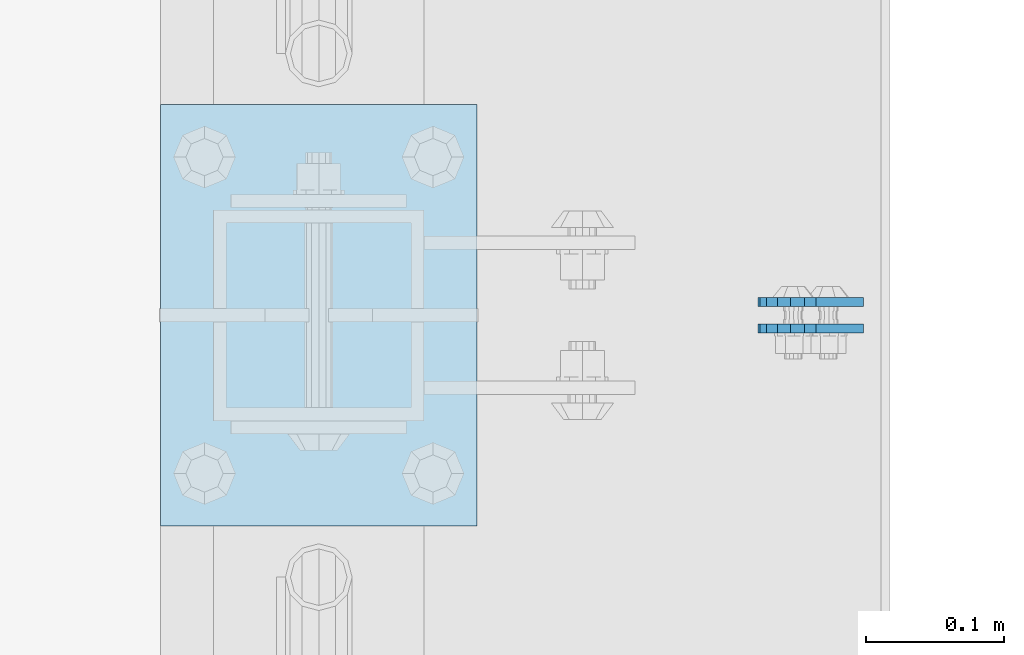
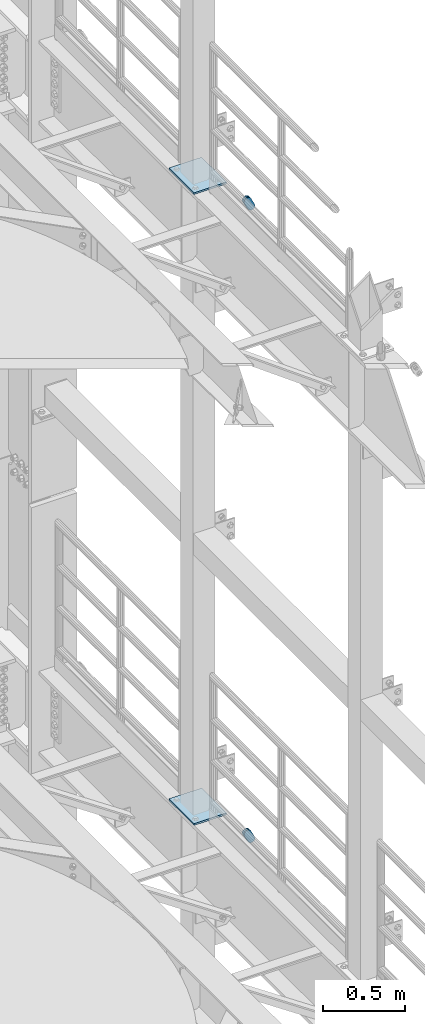
# One storey, part 1669 of 1876: 6 plates, 6 elements without a shape of their own.
"""IFC2X3 building model written with IfcOpenShell, lengths in millimetres."""

from ifc_helpers import new_model, si_unit, frame, origin_with_axes, place, context, subcontext, project, spatial, faceted_brep, material, type_object, element, aggregate, save


model = new_model("IFC2X3")

# Units and contexts
model_context = context("Model", 3, precision=1e-05, world=origin_with_axes())
body_context = subcontext(model_context, "Body", "Model", "MODEL_VIEW")
ifc_project = project(units=[si_unit("LENGTHUNIT", "METRE", prefix="MILLI"), si_unit("AREAUNIT", "SQUARE_METRE"), si_unit("VOLUMEUNIT", "CUBIC_METRE"), si_unit("MASSUNIT", "GRAM", prefix="KILO"), si_unit("TIMEUNIT", "SECOND"), si_unit("PLANEANGLEUNIT", "RADIAN"), si_unit("SOLIDANGLEUNIT", "STERADIAN"), si_unit("THERMODYNAMICTEMPERATUREUNIT", "DEGREE_CELSIUS"), si_unit("LUMINOUSINTENSITYUNIT", "LUMEN")], contexts=[model_context])

# Site, building, storey
site_placement = place(None, origin_with_axes())
site = spatial("IfcSite", under=ifc_project, at=site_placement, CompositionType="ELEMENT")
building_placement = place(site_placement, origin_with_axes())
building = spatial("IfcBuilding", under=site, at=building_placement, Name="Undefined", CompositionType="ELEMENT")
storey_placement = place(building_placement, origin_with_axes())
storey = spatial("IfcBuildingStorey", under=building, at=storey_placement, Name="Undefined", CompositionType="ELEMENT", Elevation=0.0)

# Assembly, plate
assembly_1_placement = place(storey_placement, origin_with_axes())
assembly_1 = element("IfcElementAssembly", 1, at=assembly_1_placement, inside=storey, Name="PLATE", AssemblyPlace="NOTDEFINED", PredefinedType="RIGID_FRAME")
ifc_material = material(Name="STEEL/A36")
plate_type_1 = type_object("IfcPlateType", PredefinedType="NOTDEFINED")
plate_1_placement = place(assembly_1_placement, frame((7974.16265105599, -517.524994635938, 17725.177677481), z_axis=(-0.894427191199917, 1.49999996210681e-08, -0.447213595099955), x_axis=(0.447213595099955, -6.99999707257281e-09, -0.894427191199917)))
plate_1 = element("IfcPlate", 2, at=plate_1_placement, type_object=plate_type_1, material=ifc_material, Name="PLATE", context=body_context, shape_type="Brep", body=[
    faceted_brep([(-8.59611645864788e-07, -3.17499999999654, 25.3999987589127), (1.93345873884391, -3.17499999999382, 35.1201580589886), (1.93345873884391, 3.17500000000564, 35.1201580589886), (-8.59611645864788e-07, 3.17500000000382, 25.3999987589132), (7.43948648259902, -3.17499999999109, 43.3605112870105), (7.43948648259902, 3.17500000000928, 43.3605112870105), (15.6798395242777, -3.17499999998654, 48.8665393096448), (15.6798395242777, 3.17500000001382, 48.8665393096448), (25.3999987589095, -3.17499999998199, 50.7999992370592), (25.3999987589095, 3.17500000001837, 50.7999992370592), (82.196130752618, -3.17499999998381, 50.7999992370605), (82.196130752618, 3.17500000001655, 50.7999992370642), (91.9162897887145, -3.17499999997926, 48.8665393918873), (91.9162897887145, 3.1750000000211, 48.8665393918909), (100.156642725027, -3.17499999997472, 43.3605115909359), (100.156642725027, 3.17500000002565, 43.3605115909395), (105.662670525982, -3.17499999997108, 35.1201586546285), (105.662670525986, 3.17500000002929, 35.1201586546358), (107.596130371159, -3.17499999996744, 25.3999996185757), (107.596130371159, 3.17500000003292, 25.3999996185794), (105.662670525981, -3.17499999996471, 15.6798405824902), (105.662670525981, 3.17500000003565, 15.6798405824939), (100.156642725024, -3.17499999996471, 7.43948764618654), (100.156642725025, 3.17500000003565, 7.43948764619017), (91.9162897887127, -3.17499999996562, 1.93345984522784), (91.9162897887127, 3.17500000003474, 1.93345984523148), (82.196130752618, -3.17499999996835, 4.54747350886464e-11), (82.196130752618, 3.1750000000311, 4.91127138957381e-11), (25.399998758905, -3.17499999999018, -8.64019966684282e-12), (25.399998758905, 3.17500000001019, -8.64019966684282e-12), (15.679839921364, -3.17499999999382, 1.9334597629304), (15.679839921364, 3.17500000000655, 1.9334597629304), (7.43948709043525, -3.17499999999654, 7.43948734220839), (7.43948709043525, 3.17500000000382, 7.43948734220885), (1.93345923228208, -3.17499999999654, 15.6798399868012), (1.93345923228208, 3.17500000000291, 15.6798399868012)], [[[0, 1, 2, 3]], [[1, 4, 5, 2]], [[4, 6, 7, 5]], [[6, 8, 9, 7]], [[8, 10, 11, 9]], [[10, 12, 13, 11]], [[12, 14, 15, 13]], [[14, 16, 17, 15]], [[16, 18, 19, 17]], [[18, 20, 21, 19]], [[20, 22, 23, 21]], [[22, 24, 25, 23]], [[24, 26, 27, 25]], [[26, 28, 29, 27]], [[28, 30, 31, 29]], [[30, 32, 33, 31]], [[32, 34, 35, 33]], [[34, 0, 3, 35]], [[5, 7, 9, 11, 13, 15, 17, 19, 21, 23, 25, 27, 29, 31, 33, 35, 3, 2]], [[34, 32, 30, 28, 26, 24, 22, 20, 18, 16, 14, 12, 10, 8, 6, 4, 1, 0]]]),
])
aggregate(assembly_1, [plate_1])

assembly_2_placement = place(storey_placement, origin_with_axes())
assembly_2 = element("IfcElementAssembly", 3, at=assembly_2_placement, inside=storey, Name="PLATE", AssemblyPlace="NOTDEFINED", PredefinedType="RIGID_FRAME")
plate_2_placement = place(assembly_2_placement, frame((7974.16265165258, -498.463798331259, 17725.177677481), z_axis=(-0.894427191199917, 1.49999996210681e-08, -0.447213595099955), x_axis=(0.447213595099955, -6.99999707257281e-09, -0.894427191199917)))
plate_2 = element("IfcPlate", 4, at=plate_2_placement, type_object=plate_type_1, material=ifc_material, Name="PLATE", context=body_context, shape_type="Brep", body=[
    faceted_brep([(-8.59611645864788e-07, -3.17499999999654, 25.3999987589127), (1.93345873884391, -3.17499999999382, 35.1201580589886), (1.93345873884391, 3.17500000000564, 35.1201580589886), (-8.59611645864788e-07, 3.17500000000382, 25.3999987589132), (7.43948648259902, -3.17499999999109, 43.3605112870105), (7.43948648259902, 3.17500000000928, 43.3605112870105), (15.6798395242777, -3.17499999998654, 48.8665393096448), (15.6798395242777, 3.17500000001382, 48.8665393096448), (25.3999987589095, -3.17499999998199, 50.7999992370592), (25.3999987589095, 3.17500000001837, 50.7999992370592), (82.196130752618, -3.17499999998381, 50.7999992370605), (82.196130752618, 3.17500000001655, 50.7999992370642), (91.9162897887145, -3.17499999997926, 48.8665393918873), (91.9162897887145, 3.1750000000211, 48.8665393918909), (100.156642725027, -3.17499999997472, 43.3605115909359), (100.156642725027, 3.17500000002565, 43.3605115909395), (105.662670525982, -3.17499999997108, 35.1201586546285), (105.662670525986, 3.17500000002929, 35.1201586546358), (107.596130371159, -3.17499999996744, 25.3999996185757), (107.596130371159, 3.17500000003292, 25.3999996185794), (105.662670525981, -3.17499999996471, 15.6798405824902), (105.662670525981, 3.17500000003565, 15.6798405824939), (100.156642725024, -3.17499999996471, 7.43948764618654), (100.156642725025, 3.17500000003565, 7.43948764619017), (91.9162897887127, -3.17499999996562, 1.93345984522784), (91.9162897887127, 3.17500000003474, 1.93345984523148), (82.196130752618, -3.17499999996835, 4.54747350886464e-11), (82.196130752618, 3.1750000000311, 4.91127138957381e-11), (25.399998758905, -3.17499999999018, -8.64019966684282e-12), (25.399998758905, 3.17500000001019, -8.64019966684282e-12), (15.679839921364, -3.17499999999382, 1.9334597629304), (15.679839921364, 3.17500000000655, 1.9334597629304), (7.43948709043525, -3.17499999999654, 7.43948734220839), (7.43948709043525, 3.17500000000382, 7.43948734220885), (1.93345923228208, -3.17499999999654, 15.6798399868012), (1.93345923228208, 3.17500000000291, 15.6798399868012)], [[[0, 1, 2, 3]], [[1, 4, 5, 2]], [[4, 6, 7, 5]], [[6, 8, 9, 7]], [[8, 10, 11, 9]], [[10, 12, 13, 11]], [[12, 14, 15, 13]], [[14, 16, 17, 15]], [[16, 18, 19, 17]], [[18, 20, 21, 19]], [[20, 22, 23, 21]], [[22, 24, 25, 23]], [[24, 26, 27, 25]], [[26, 28, 29, 27]], [[28, 30, 31, 29]], [[30, 32, 33, 31]], [[32, 34, 35, 33]], [[34, 0, 3, 35]], [[5, 7, 9, 11, 13, 15, 17, 19, 21, 23, 25, 27, 29, 31, 33, 35, 3, 2]], [[34, 32, 30, 28, 26, 24, 22, 20, 18, 16, 14, 12, 10, 8, 6, 4, 1, 0]]]),
])
aggregate(assembly_2, [plate_2])

assembly_3_placement = place(storey_placement, origin_with_axes())
assembly_3 = element("IfcElementAssembly", 5, at=assembly_3_placement, inside=storey, Name="PLATE", AssemblyPlace="NOTDEFINED", PredefinedType="RIGID_FRAME")
plate_3_placement = place(assembly_3_placement, frame((7974.16265105599, -517.524994635938, 13038.8776774809), z_axis=(-0.894427191199917, 1.49999996210681e-08, -0.447213595099955), x_axis=(0.447213595099955, -6.99999707257281e-09, -0.894427191199917)))
plate_3 = element("IfcPlate", 6, at=plate_3_placement, type_object=plate_type_1, material=ifc_material, Name="PLATE", context=body_context, shape_type="Brep", body=[
    faceted_brep([(-8.59611645864788e-07, -3.17499999999654, 25.3999987589127), (1.93345873884391, -3.17499999999382, 35.1201580589886), (1.93345873884391, 3.17500000000564, 35.1201580589886), (-8.59611645864788e-07, 3.17500000000382, 25.3999987589132), (7.43948648259902, -3.17499999999109, 43.3605112870105), (7.43948648259902, 3.17500000000928, 43.3605112870105), (15.6798395242777, -3.17499999998654, 48.8665393096448), (15.6798395242777, 3.17500000001382, 48.8665393096448), (25.3999987589095, -3.17499999998199, 50.7999992370592), (25.3999987589095, 3.17500000001837, 50.7999992370592), (82.196130752618, -3.17499999998381, 50.7999992370605), (82.196130752618, 3.17500000001655, 50.7999992370642), (91.9162897887145, -3.17499999997926, 48.8665393918873), (91.9162897887145, 3.1750000000211, 48.8665393918909), (100.156642725027, -3.17499999997472, 43.3605115909359), (100.156642725027, 3.17500000002565, 43.3605115909395), (105.662670525982, -3.17499999997108, 35.1201586546285), (105.662670525986, 3.17500000002929, 35.1201586546358), (107.596130371159, -3.17499999996744, 25.3999996185757), (107.596130371159, 3.17500000003292, 25.3999996185794), (105.662670525981, -3.17499999996471, 15.6798405824902), (105.662670525981, 3.17500000003565, 15.6798405824939), (100.156642725024, -3.17499999996471, 7.43948764618654), (100.156642725025, 3.17500000003565, 7.43948764619017), (91.9162897887127, -3.17499999996562, 1.93345984522784), (91.9162897887127, 3.17500000003474, 1.93345984523148), (82.196130752618, -3.17499999996835, 4.54747350886464e-11), (82.196130752618, 3.1750000000311, 4.91127138957381e-11), (25.399998758905, -3.17499999999018, -8.64019966684282e-12), (25.399998758905, 3.17500000001019, -8.64019966684282e-12), (15.679839921364, -3.17499999999382, 1.9334597629304), (15.679839921364, 3.17500000000655, 1.9334597629304), (7.43948709043525, -3.17499999999654, 7.43948734220839), (7.43948709043525, 3.17500000000382, 7.43948734220885), (1.93345923228208, -3.17499999999654, 15.6798399868012), (1.93345923228208, 3.17500000000291, 15.6798399868012)], [[[0, 1, 2, 3]], [[1, 4, 5, 2]], [[4, 6, 7, 5]], [[6, 8, 9, 7]], [[8, 10, 11, 9]], [[10, 12, 13, 11]], [[12, 14, 15, 13]], [[14, 16, 17, 15]], [[16, 18, 19, 17]], [[18, 20, 21, 19]], [[20, 22, 23, 21]], [[22, 24, 25, 23]], [[24, 26, 27, 25]], [[26, 28, 29, 27]], [[28, 30, 31, 29]], [[30, 32, 33, 31]], [[32, 34, 35, 33]], [[34, 0, 3, 35]], [[5, 7, 9, 11, 13, 15, 17, 19, 21, 23, 25, 27, 29, 31, 33, 35, 3, 2]], [[34, 32, 30, 28, 26, 24, 22, 20, 18, 16, 14, 12, 10, 8, 6, 4, 1, 0]]]),
])
aggregate(assembly_3, [plate_3])

assembly_4_placement = place(storey_placement, origin_with_axes())
assembly_4 = element("IfcElementAssembly", 7, at=assembly_4_placement, inside=storey, Name="PLATE", AssemblyPlace="NOTDEFINED", PredefinedType="RIGID_FRAME")
plate_4_placement = place(assembly_4_placement, frame((7974.16265165258, -498.463798331259, 13038.8776774809), z_axis=(-0.894427191199917, 1.49999996210681e-08, -0.447213595099955), x_axis=(0.447213595099955, -6.99999707257281e-09, -0.894427191199917)))
plate_4 = element("IfcPlate", 8, at=plate_4_placement, type_object=plate_type_1, material=ifc_material, Name="PLATE", context=body_context, shape_type="Brep", body=[
    faceted_brep([(-8.59611645864788e-07, -3.17499999999654, 25.3999987589127), (1.93345873884391, -3.17499999999382, 35.1201580589886), (1.93345873884391, 3.17500000000564, 35.1201580589886), (-8.59611645864788e-07, 3.17500000000382, 25.3999987589132), (7.43948648259902, -3.17499999999109, 43.3605112870105), (7.43948648259902, 3.17500000000928, 43.3605112870105), (15.6798395242777, -3.17499999998654, 48.8665393096448), (15.6798395242777, 3.17500000001382, 48.8665393096448), (25.3999987589095, -3.17499999998199, 50.7999992370592), (25.3999987589095, 3.17500000001837, 50.7999992370592), (82.196130752618, -3.17499999998381, 50.7999992370605), (82.196130752618, 3.17500000001655, 50.7999992370642), (91.9162897887145, -3.17499999997926, 48.8665393918873), (91.9162897887145, 3.1750000000211, 48.8665393918909), (100.156642725027, -3.17499999997472, 43.3605115909359), (100.156642725027, 3.17500000002565, 43.3605115909395), (105.662670525982, -3.17499999997108, 35.1201586546285), (105.662670525986, 3.17500000002929, 35.1201586546358), (107.596130371159, -3.17499999996744, 25.3999996185757), (107.596130371159, 3.17500000003292, 25.3999996185794), (105.662670525981, -3.17499999996471, 15.6798405824902), (105.662670525981, 3.17500000003565, 15.6798405824939), (100.156642725024, -3.17499999996471, 7.43948764618654), (100.156642725025, 3.17500000003565, 7.43948764619017), (91.9162897887127, -3.17499999996562, 1.93345984522784), (91.9162897887127, 3.17500000003474, 1.93345984523148), (82.196130752618, -3.17499999996835, 4.54747350886464e-11), (82.196130752618, 3.1750000000311, 4.91127138957381e-11), (25.399998758905, -3.17499999999018, -8.64019966684282e-12), (25.399998758905, 3.17500000001019, -8.64019966684282e-12), (15.679839921364, -3.17499999999382, 1.9334597629304), (15.679839921364, 3.17500000000655, 1.9334597629304), (7.43948709043525, -3.17499999999654, 7.43948734220839), (7.43948709043525, 3.17500000000382, 7.43948734220885), (1.93345923228208, -3.17499999999654, 15.6798399868012), (1.93345923228208, 3.17500000000291, 15.6798399868012)], [[[0, 1, 2, 3]], [[1, 4, 5, 2]], [[4, 6, 7, 5]], [[6, 8, 9, 7]], [[8, 10, 11, 9]], [[10, 12, 13, 11]], [[12, 14, 15, 13]], [[14, 16, 17, 15]], [[16, 18, 19, 17]], [[18, 20, 21, 19]], [[20, 22, 23, 21]], [[22, 24, 25, 23]], [[24, 26, 27, 25]], [[26, 28, 29, 27]], [[28, 30, 31, 29]], [[30, 32, 33, 31]], [[32, 34, 35, 33]], [[34, 0, 3, 35]], [[5, 7, 9, 11, 13, 15, 17, 19, 21, 23, 25, 27, 29, 31, 33, 35, 3, 2]], [[34, 32, 30, 28, 26, 24, 22, 20, 18, 16, 14, 12, 10, 8, 6, 4, 1, 0]]]),
])
aggregate(assembly_4, [plate_4])

assembly_5_placement = place(storey_placement, origin_with_axes())
assembly_5 = element("IfcElementAssembly", 9, at=assembly_5_placement, inside=storey, Name="BEAM", AssemblyPlace="NOTDEFINED", PredefinedType="RIGID_FRAME")
plate_type_2 = type_object("IfcPlateType", PredefinedType="NOTDEFINED")
plate_5_placement = place(assembly_5_placement, frame((7505.7, -660.400000000001, 17989.55), z_axis=(0.0, 1.0, 0.0), x_axis=(1.0, 0.0, 0.0)))
plate_5 = element("IfcPlate", 10, at=plate_5_placement, type_object=plate_type_2, material=ifc_material, Name="PLATE", context=body_context, shape_type="Brep", body=[
    faceted_brep([(0.0, -6.35000000000036, 0.0), (0.0, -6.35000000000036, 304.799987792969), (0.0, 6.35000000000036, 304.799987792969), (0.0, 6.35000000000036, 0.0), (228.600006103516, -6.34999999999854, 304.799987792969), (228.600006103516, 6.34999999999854, 304.799987792969), (228.600006103516, -6.34999999999854, 0.0), (228.600006103516, 6.34999999999854, 0.0)], [[[0, 1, 2, 3]], [[1, 4, 5, 2]], [[4, 6, 7, 5]], [[6, 0, 3, 7]], [[5, 7, 3, 2]], [[6, 4, 1, 0]]]),
])
aggregate(assembly_5, [plate_5])

assembly_6_placement = place(storey_placement, origin_with_axes())
assembly_6 = element("IfcElementAssembly", 11, at=assembly_6_placement, inside=storey, Name="BEAM", AssemblyPlace="NOTDEFINED", PredefinedType="RIGID_FRAME")
plate_6_placement = place(assembly_6_placement, frame((7505.7, -660.400000000001, 13315.95), z_axis=(0.0, 1.0, 0.0), x_axis=(1.0, 0.0, 0.0)))
plate_6 = element("IfcPlate", 12, at=plate_6_placement, type_object=plate_type_2, material=ifc_material, Name="PLATE", context=body_context, shape_type="Brep", body=[
    faceted_brep([(0.0, -6.35000000000036, 0.0), (0.0, -6.35000000000036, 304.799987792969), (0.0, 6.35000000000036, 304.799987792969), (0.0, 6.35000000000036, 0.0), (228.600006103516, -6.34999999999854, 304.799987792969), (228.600006103516, 6.34999999999854, 304.799987792969), (228.600006103516, -6.34999999999854, 0.0), (228.600006103516, 6.34999999999854, 0.0)], [[[0, 1, 2, 3]], [[1, 4, 5, 2]], [[4, 6, 7, 5]], [[6, 0, 3, 7]], [[5, 7, 3, 2]], [[6, 4, 1, 0]]]),
])
aggregate(assembly_6, [plate_6])

save(model, "model.ifc")
